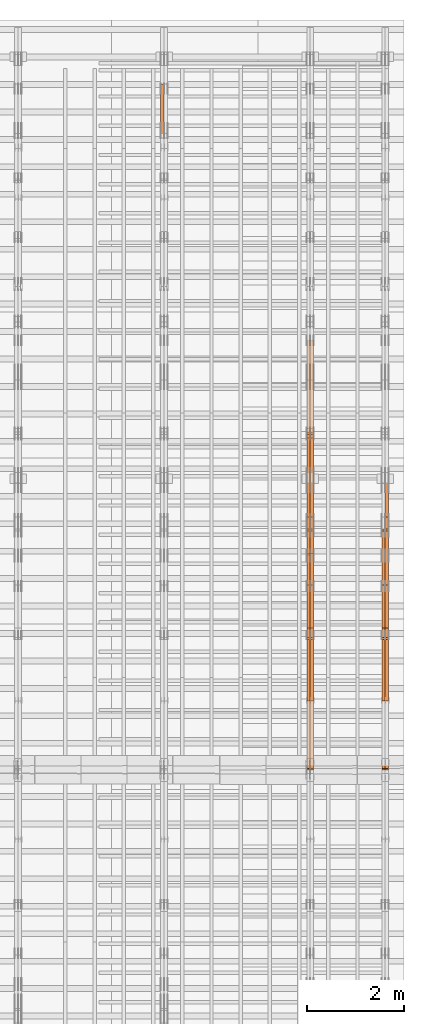
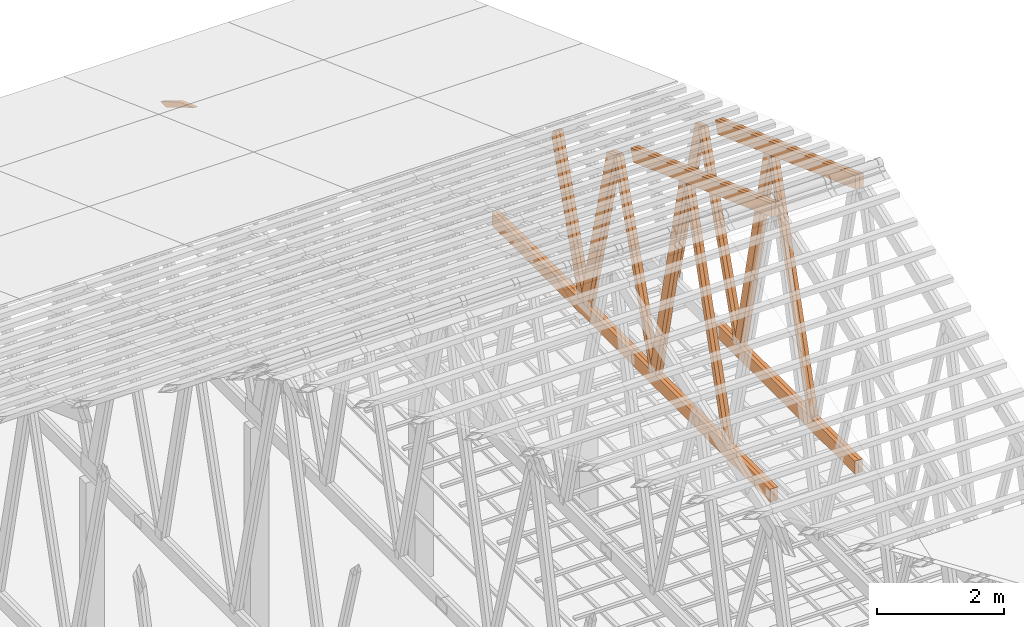
# One storey, part 64 of 189: 28 proxies.
"""IFC2X3 building model written with IfcOpenShell, lengths in millimetres."""

import ifcopenshell
import ifcopenshell.guid

model = None  # the IFC model being written
_history = None  # IfcOwnerHistory: only IFC2X3 demands one
_inside = {}  # id of a spatial element -> (the spatial element, [elements in it])
_under = {}  # id of a project, library or spatial element -> (it, [spatial elements below it])
_declared = {}  # id of a project -> (the project, [libraries it declares])
_typed = {}  # id of a type object -> (the type object, [elements of that type])
_made_of = {}  # id of a material, layer set ... -> (it, [elements and type objects made of it])


def new_model(schema):
    """Start an empty IFC model of exactly this schema.

    Asked for "IFC4X3", IfcOpenShell would pick the latest addendum, in which some entities
    have other attributes; the version numbers below select the first issue.
    IFC2X3 requires an IfcOwnerHistory on every rooted entity: one is made here for all.
    """
    global model, _history
    if schema == "IFC4X3":
        model = ifcopenshell.file(schema_version=(4, 3, 0, 0))
    else:
        model = ifcopenshell.file(schema=schema)
    _inside.clear()
    _under.clear()
    _declared.clear()
    _typed.clear()
    _made_of.clear()
    _history = None
    if model.schema == "IFC2X3":
        org = make("IfcOrganization", Name="unknown")
        user = make(
            "IfcPersonAndOrganization",
            ThePerson=make("IfcPerson", FamilyName="unknown"),
            TheOrganization=org,
        )
        app = make(
            "IfcApplication",
            ApplicationDeveloper=org,
            Version="unknown",
            ApplicationFullName="unknown",
            ApplicationIdentifier="unknown",
        )
        _history = make(
            "IfcOwnerHistory",
            OwningUser=user,
            OwningApplication=app,
            ChangeAction="ADDED",
            CreationDate=0,
        )
    return model


def make(cls, **values):
    """One entity of the class cls with the attributes given. An attribute that is None is left unset."""
    return model.create_entity(
        cls, **{name: value for name, value in values.items() if value is not None}
    )


def entity(cls, *values):
    """Any entity or typed value of the class cls, its attributes in the order of the schema. None: left unset."""
    e = model.create_entity(cls)
    for i, value in enumerate(values):
        if value is not None:
            e[i] = value
    return e


def rooted(cls, **values):
    """An entity with a GlobalId (a new one), such as an element, a storey or a relation."""
    return make(cls, GlobalId=ifcopenshell.guid.new(), OwnerHistory=_history, **values)


def si_unit(unit_type, name, prefix=None):
    """IfcSIUnit, for example si_unit("LENGTHUNIT", "METRE", prefix="MILLI")."""
    return make("IfcSIUnit", UnitType=unit_type, Prefix=prefix, Name=name)


def converted_unit(unit_type, name, factor, base, dimensions=None, offset=None):
    """IfcConversionBasedUnit, such as the inch: factor (a typed value) times the base unit."""
    return make(
        "IfcConversionBasedUnit"
        if offset is None
        else "IfcConversionBasedUnitWithOffset",
        ConversionOffset=offset,
        Dimensions=None
        if dimensions is None
        else entity("IfcDimensionalExponents", *dimensions),
        UnitType=unit_type,
        Name=name,
        ConversionFactor=make(
            "IfcMeasureWithUnit", ValueComponent=factor, UnitComponent=base
        ),
    )


def derived_unit(unit_type, elements):
    """IfcDerivedUnit: a product of units, each with its exponent."""
    return make(
        "IfcDerivedUnit",
        Elements=[
            make("IfcDerivedUnitElement", Unit=unit, Exponent=power)
            for unit, power in elements
        ],
        UnitType=unit_type,
    )


def assignment(units):
    """IfcUnitAssignment: the units of a project."""
    return None if units is None else make("IfcUnitAssignment", Units=units)


def point(xyz):
    """IfcCartesianPoint."""
    return None if xyz is None else make("IfcCartesianPoint", Coordinates=xyz)


def direction(xyz):
    """IfcDirection."""
    return None if xyz is None else make("IfcDirection", DirectionRatios=xyz)


def frame(location, z_axis=None, x_axis=None):
    """IfcAxis2Placement3D, a coordinate frame: its origin and axes. An axis left out is left unset."""
    return make(
        "IfcAxis2Placement3D",
        Location=point(location),
        Axis=direction(z_axis),
        RefDirection=direction(x_axis),
    )


def frame_2d(location, x_axis=None):
    """IfcAxis2Placement2D, a coordinate frame in the plane: its origin and x axis."""
    return make(
        "IfcAxis2Placement2D", Location=point(location), RefDirection=direction(x_axis)
    )


def origin():
    """The frame at (0, 0, 0) with its axes left unset."""
    return frame((0.0, 0.0, 0.0))


def origin_2d_with_axis():
    """The frame at (0, 0) in the plane with the x axis (1, 0) written out."""
    return frame_2d((0.0, 0.0), x_axis=(1.0, 0.0))


def place(relative_to, where):
    """IfcLocalPlacement: puts the frame where relative to a parent placement (None: the world)."""
    return make(
        "IfcLocalPlacement", PlacementRelTo=relative_to, RelativePlacement=where
    )


def context(
    kind, dimensions, precision=None, world=None, true_north=None, identifier=None
):
    """IfcGeometricRepresentationContext, for example the 3D "Model" context."""
    return make(
        "IfcGeometricRepresentationContext",
        ContextIdentifier=identifier,
        ContextType=kind,
        CoordinateSpaceDimension=dimensions,
        Precision=precision,
        WorldCoordinateSystem=world,
        TrueNorth=true_north,
    )


def subcontext(parent, identifier, kind, view, scale=None):
    """IfcGeometricRepresentationSubContext, for example "Body" below "Model"."""
    return make(
        "IfcGeometricRepresentationSubContext",
        ContextIdentifier=identifier,
        ContextType=kind,
        ParentContext=parent,
        TargetScale=scale,
        TargetView=view,
    )


def project(units=None, contexts=None):
    """IfcProject with its units and contexts."""
    return rooted(
        "IfcProject",
        Name="project",
        RepresentationContexts=contexts,
        UnitsInContext=assignment(units),
    )


def spatial(cls, under=None, at=None, **own):
    """A site, building, storey or space (cls), placed at a placement, below another one or the project."""
    s = rooted(cls, ObjectPlacement=at, **own)
    if under is not None:
        _under.setdefault(under.id(), (under, []))[1].append(s)
    return s


def polyline(points):
    """IfcPolyline through the points."""
    return make("IfcPolyline", Points=[point(p) for p in points])


def profile(cls, at=None, kind="AREA", **sizes):
    """A parametric profile (cls). Its sizes go by their IFC names, for example OverallWidth=200.0."""
    return make(cls, ProfileType=kind, Position=at, **sizes)


def rectangle(**sizes):
    """IfcRectangleProfileDef."""
    return profile("IfcRectangleProfileDef", **sizes)


def outline(outer, holes=None, kind="AREA"):
    """IfcArbitraryClosedProfileDef: a profile drawn as a closed curve; with holes, ...WithVoids."""
    if holes is None:
        return make("IfcArbitraryClosedProfileDef", ProfileType=kind, OuterCurve=outer)
    return make(
        "IfcArbitraryProfileDefWithVoids",
        ProfileType=kind,
        OuterCurve=outer,
        InnerCurves=holes,
    )


def extrude(swept, where, along, depth):
    """IfcExtrudedAreaSolid: the profile swept, set in the frame where, extruded along a direction by depth."""
    return make(
        "IfcExtrudedAreaSolid",
        SweptArea=swept,
        Position=where,
        ExtrudedDirection=direction(along),
        Depth=depth,
    )


def shape(context_of_items, identifier, shape_type, items):
    """IfcShapeRepresentation: the items that make up one representation, for example the "Body"."""
    return make(
        "IfcShapeRepresentation",
        ContextOfItems=context_of_items,
        RepresentationIdentifier=identifier,
        RepresentationType=shape_type,
        Items=items,
    )


def source(mapping_origin, context_of_items, identifier, shape_type, items):
    """IfcRepresentationMap: a shape defined once, which mapped items show again and again."""
    return make(
        "IfcRepresentationMap",
        MappingOrigin=mapping_origin,
        MappedRepresentation=shape(context_of_items, identifier, shape_type, items),
    )


def transform(
    local_origin,
    x_axis=None,
    y_axis=None,
    z_axis=None,
    scale=None,
    scale2=None,
    scale3=None,
    uniform=True,
):
    """IfcCartesianTransformationOperator3D, or its non-uniform kind. x_axis, y_axis, z_axis: its Axis1, 2, 3."""
    if uniform:
        return make(
            "IfcCartesianTransformationOperator3D",
            Axis1=direction(x_axis),
            Axis2=direction(y_axis),
            LocalOrigin=point(local_origin),
            Scale=scale,
            Axis3=direction(z_axis),
        )
    return make(
        "IfcCartesianTransformationOperator3DnonUniform",
        Axis1=direction(x_axis),
        Axis2=direction(y_axis),
        LocalOrigin=point(local_origin),
        Scale=scale,
        Axis3=direction(z_axis),
        Scale2=scale2,
        Scale3=scale3,
    )


def mapped(mapping_source, mapping_target):
    """IfcMappedItem: shows the shape of a source again, moved by a transform."""
    return make(
        "IfcMappedItem", MappingSource=mapping_source, MappingTarget=mapping_target
    )


def material(Name=None, Category=None):
    """IfcMaterial."""
    return make("IfcMaterial", Name=Name, Category=Category)


def made_of(thing, what):
    """Note that an element or type object is made of a material, layer set ...; save() writes the relation."""
    if what is not None:
        _made_of.setdefault(what.id(), (what, []))[1].append(thing)
    return thing


def type_object(cls, material=None, **own):
    """A type object (cls), such as IfcWallType, which elements share."""
    return made_of(rooted(cls, **own), material)


def type_shapes(of_type, sources):
    """Give a type object the sources (RepresentationMaps) that its elements show as mapped items."""
    of_type.RepresentationMaps = sources


def element(
    cls,
    number,
    at=None,
    inside=None,
    cuts=None,
    type_object=None,
    material=None,
    context=None,
    identifier="Body",
    shape_type=None,
    held_by="IfcProductDefinitionShape",
    body=None,
    shapes=None,
    **own,
):
    """One element of the class cls, such as IfcWall. Its Tag is "e" and its number.

    at: its placement. inside: the storey or other place that contains it. cuts: it is an
    opening in that element (IfcRelVoidsElement). A single representation is given by context,
    identifier, shape_type and body (its items); several are given by shapes. held_by: the class
    of the entity that holds the representations. save() writes the other relations.
    """
    e = rooted(cls, Tag="e%d" % number, ObjectPlacement=at, **own)
    if body is not None:
        shapes = [shape(context, identifier, shape_type, body)]
    if shapes is not None:
        e.Representation = make(held_by, Representations=shapes)
    if inside is not None:
        _inside.setdefault(inside.id(), (inside, []))[1].append(e)
    if cuts is not None:
        rooted(
            "IfcRelVoidsElement", RelatingBuildingElement=cuts, RelatedOpeningElement=e
        )
    if type_object is not None:
        _typed.setdefault(type_object.id(), (type_object, []))[1].append(e)
    return made_of(e, material)


def aggregate(whole, parts):
    """IfcRelAggregates: a whole, such as a stair, and the parts it consists of."""
    return rooted("IfcRelAggregates", RelatingObject=whole, RelatedObjects=parts)


def save(model, path):
    """Write the relations noted so far, then the file.

    IfcRelAggregates (storeys below a building ...), IfcRelContainedInSpatialStructure (elements
    in a storey), IfcRelDefinesByType, IfcRelAssociatesMaterial and IfcRelDeclares: one each for
    every whole, place, type object, material and project.
    """
    for whole, parts in _under.values():
        aggregate(whole, parts)
    for where, things in _inside.values():
        rooted(
            "IfcRelContainedInSpatialStructure",
            RelatedElements=things,
            RelatingStructure=where,
        )
    for kind, things in _typed.values():
        rooted("IfcRelDefinesByType", RelatedObjects=things, RelatingType=kind)
    for what, things in _made_of.values():
        rooted("IfcRelAssociatesMaterial", RelatedObjects=things, RelatingMaterial=what)
    for by, libraries in _declared.values():
        rooted("IfcRelDeclares", RelatingContext=by, RelatedDefinitions=libraries)
    model.write(path)


model = new_model("IFC2X3")

# Units and contexts
model_context = context("Model", 3, precision=0.01, world=origin(), true_north=direction((6.12303176911189e-17, 1.0)))
body_context = subcontext(model_context, "Body", "Model", "MODEL_VIEW")
ifc_project = project(units=[si_unit("LENGTHUNIT", "METRE", prefix="MILLI"), si_unit("AREAUNIT", "SQUARE_METRE"), si_unit("VOLUMEUNIT", "CUBIC_METRE"), converted_unit("PLANEANGLEUNIT", "DEGREE", entity("IfcRatioMeasure", 0.0174532925199433), si_unit("PLANEANGLEUNIT", "RADIAN"), dimensions=[0, 0, 0, 0, 0, 0, 0]), si_unit("MASSUNIT", "GRAM", prefix="KILO"), derived_unit("MASSDENSITYUNIT", [(si_unit("MASSUNIT", "GRAM", prefix="KILO"), 1), (si_unit("LENGTHUNIT", "METRE"), -3)]), si_unit("TIMEUNIT", "SECOND"), si_unit("FREQUENCYUNIT", "HERTZ"), si_unit("THERMODYNAMICTEMPERATUREUNIT", "DEGREE_CELSIUS"), derived_unit("THERMALTRANSMITTANCEUNIT", [(si_unit("MASSUNIT", "GRAM", prefix="KILO"), 1), (si_unit("THERMODYNAMICTEMPERATUREUNIT", "KELVIN"), -1), (si_unit("TIMEUNIT", "SECOND"), -3)]), derived_unit("VOLUMETRICFLOWRATEUNIT", [(si_unit("LENGTHUNIT", "METRE"), 3), (si_unit("TIMEUNIT", "SECOND"), -1)]), si_unit("ELECTRICCURRENTUNIT", "AMPERE"), si_unit("ELECTRICVOLTAGEUNIT", "VOLT"), si_unit("POWERUNIT", "WATT"), si_unit("FORCEUNIT", "NEWTON"), si_unit("ILLUMINANCEUNIT", "LUX"), si_unit("LUMINOUSFLUXUNIT", "LUMEN"), si_unit("LUMINOUSINTENSITYUNIT", "CANDELA"), derived_unit("USERDEFINED", [(si_unit("MASSUNIT", "GRAM", prefix="KILO"), -1), (si_unit("LENGTHUNIT", "METRE"), -2), (si_unit("TIMEUNIT", "SECOND"), 3), (si_unit("LUMINOUSFLUXUNIT", "LUMEN"), 1)]), derived_unit("LINEARVELOCITYUNIT", [(si_unit("LENGTHUNIT", "METRE"), 1), (si_unit("TIMEUNIT", "SECOND"), -1)]), si_unit("PRESSUREUNIT", "PASCAL"), derived_unit("USERDEFINED", [(si_unit("LENGTHUNIT", "METRE"), -2), (si_unit("MASSUNIT", "GRAM", prefix="KILO"), 1), (si_unit("TIMEUNIT", "SECOND"), -2)])], contexts=[model_context])

# Site, building, storey
site_placement = place(None, origin())
site = spatial("IfcSite", under=ifc_project, at=site_placement, CompositionType="ELEMENT")
building_placement = place(site_placement, origin())
building = spatial("IfcBuilding", under=site, at=building_placement, CompositionType="ELEMENT")
storey_placement = place(building_placement, origin())
storey = spatial("IfcBuildingStorey", under=building, at=storey_placement, Name="Default", CompositionType="ELEMENT", Elevation=0.0)

# Proxies
ifc_material_1 = material(Name="IfcSurfaceStyle #273508")
building_element_proxy_type_1 = type_object("IfcBuildingElementProxyType", Name="T1-W6 273506", PredefinedType="NOTDEFINED", material=ifc_material_1)
shared_shape_1 = source(origin(), body_context, "Body", "SweptSolid", [
    extrude(outline(polyline([(-2668.68989660745, -47.5002238228721), (1800.72567700045, -47.5002238228721), (1797.68490303083, 0.000158637170537834), (1711.12272493628, 47.5001445042868), (-2640.84340836012, 47.5001445042868), (-2668.68989660745, -47.5002238228721)])), frame((1800.7257704503, 47.5001445042868, 0.0), z_axis=(0.0, 0.0, 1.0), x_axis=(-1.0, 0.0, 0.0)), (0.0, 0.0, 1.0), 69.9999999999997),
])
type_shapes(building_element_proxy_type_1, [shared_shape_1])
proxy_1_placement = place(building_placement, frame((49840.0, 17516.8749791841, 4507.23620831254), z_axis=(-1.0, 0.0, 0.0), x_axis=(0.0, -0.281285983104611, -0.959623986626466)))
element("IfcBuildingElementProxy", 1, at=proxy_1_placement, inside=storey, type_object=building_element_proxy_type_1, material=ifc_material_1, Name="T1-W6", context=body_context, shape_type="MappedRepresentation", body=[
    mapped(shared_shape_1, transform((0.0, 0.0, 0.0), scale=1.0)),
])
ifc_material_2 = material(Name="IfcSurfaceStyle #273442")
building_element_proxy_type_2 = type_object("IfcBuildingElementProxyType", Name="T1-W6 273440", PredefinedType="NOTDEFINED", material=ifc_material_2)
shared_shape_2 = source(origin(), body_context, "Body", "SweptSolid", [
    extrude(outline(polyline([(-2668.68989660745, -47.5002238228721), (1800.72567700045, -47.5002238228721), (1797.68490303083, 0.000158637170537834), (1711.12272493628, 47.5001445042868), (-2640.84340836012, 47.5001445042868), (-2668.68989660745, -47.5002238228721)])), frame((1800.7257704503, 47.5001445042868, 0.0), z_axis=(0.0, 0.0, 1.0), x_axis=(-1.0, 0.0, 0.0)), (0.0, 0.0, 1.0), 69.9999999999997),
])
type_shapes(building_element_proxy_type_2, [shared_shape_2])
proxy_2_placement = place(building_placement, frame((49770.0, 17516.8749791841, 4507.23620831254), z_axis=(-1.0, 0.0, 0.0), x_axis=(0.0, -0.281285983104611, -0.959623986626466)))
element("IfcBuildingElementProxy", 2, at=proxy_2_placement, inside=storey, type_object=building_element_proxy_type_2, material=ifc_material_2, Name="T1-W6", context=body_context, shape_type="MappedRepresentation", body=[
    mapped(shared_shape_2, transform((0.0, 0.0, 0.0), scale=1.0)),
])
ifc_material_3 = material(Name="IfcSurfaceStyle #273244")
building_element_proxy_type_3 = type_object("IfcBuildingElementProxyType", Name="T1-W3 273242", PredefinedType="NOTDEFINED", material=ifc_material_3)
shared_shape_3 = source(origin(), body_context, "Body", "SweptSolid", [
    extrude(outline(polyline([(-2517.58938959787, -85.0001104675026), (1625.445846867, -85.0001104675027), (1768.20563426494, 0.000209440697654673), (1749.48871563991, 85.0000057471538), (-2625.55080717397, 85.0000057471538), (-2517.58938959787, -85.0001104675026)])), frame((1768.2056683344, 85.0000547211315, 0.0), z_axis=(0.0, 0.0, 1.0), x_axis=(-1.0, 0.0, 0.0)), (0.0, 0.0, 1.0), 69.9999999999997),
])
type_shapes(building_element_proxy_type_3, [shared_shape_3])
proxy_3_placement = place(building_placement, frame((49840.0, 18415.3042863408, 226.720947016584), z_axis=(-1.0, 0.0, 0.0), x_axis=(0.0, -0.215047682154604, 0.976603550269982)))
element("IfcBuildingElementProxy", 3, at=proxy_3_placement, inside=storey, type_object=building_element_proxy_type_3, material=ifc_material_3, Name="T1-W3", context=body_context, shape_type="MappedRepresentation", body=[
    mapped(shared_shape_3, transform((0.0, 0.0, 0.0), scale=1.0)),
])
ifc_material_4 = material(Name="IfcSurfaceStyle #273178")
building_element_proxy_type_4 = type_object("IfcBuildingElementProxyType", Name="T1-W3 273176", PredefinedType="NOTDEFINED", material=ifc_material_4)
shared_shape_4 = source(origin(), body_context, "Body", "SweptSolid", [
    extrude(outline(polyline([(-2517.58938959787, -85.0001104675026), (1625.445846867, -85.0001104675027), (1768.20563426494, 0.000209440697654673), (1749.48871563991, 85.0000057471538), (-2625.55080717397, 85.0000057471538), (-2517.58938959787, -85.0001104675026)])), frame((1768.2056683344, 85.0000547211315, 0.0), z_axis=(0.0, 0.0, 1.0), x_axis=(-1.0, 0.0, 0.0)), (0.0, 0.0, 1.0), 69.9999999999997),
])
type_shapes(building_element_proxy_type_4, [shared_shape_4])
proxy_4_placement = place(building_placement, frame((49770.0, 18415.3042863408, 226.720947016584), z_axis=(-1.0, 0.0, 0.0), x_axis=(0.0, -0.215047682154604, 0.976603550269982)))
element("IfcBuildingElementProxy", 4, at=proxy_4_placement, inside=storey, type_object=building_element_proxy_type_4, material=ifc_material_4, Name="T1-W3", context=body_context, shape_type="MappedRepresentation", body=[
    mapped(shared_shape_4, transform((0.0, 0.0, 0.0), scale=1.0)),
])
ifc_material_5 = material(Name="IfcSurfaceStyle #272980")
building_element_proxy_type_5 = type_object("IfcBuildingElementProxyType", Name="T1-W7 272978", PredefinedType="NOTDEFINED", material=ifc_material_5)
shared_shape_5 = source(origin(), body_context, "Body", "SweptSolid", [
    extrude(outline(polyline([(-2189.6662270939, -47.5000140805343), (1475.30081553583, -47.5000140805343), (1473.93388518462, 0.00042343352179337), (1398.58463533215, 47.4998023637734), (-2158.15310895869, 47.4998023637734), (-2189.6662270939, -47.5000140805343)])), frame((1475.30081553583, 47.5004895824757, 0.0), z_axis=(0.0, 0.0, 1.0), x_axis=(-1.0, 0.0, 0.0)), (0.0, 0.0, 1.0), 69.9999999999998),
])
type_shapes(building_element_proxy_type_5, [shared_shape_5])
proxy_5_placement = place(building_placement, frame((49840.0, 19742.3819153401, 3693.66743808885), z_axis=(-1.0, 0.0, 0.0), x_axis=(0.0, -0.314845237923104, -0.949143021971475)))
element("IfcBuildingElementProxy", 5, at=proxy_5_placement, inside=storey, type_object=building_element_proxy_type_5, material=ifc_material_5, Name="T1-W7", context=body_context, shape_type="MappedRepresentation", body=[
    mapped(shared_shape_5, transform((0.0, 0.0, 0.0), scale=1.0)),
])
ifc_material_6 = material(Name="IfcSurfaceStyle #272914")
building_element_proxy_type_6 = type_object("IfcBuildingElementProxyType", Name="T1-W7 272912", PredefinedType="NOTDEFINED", material=ifc_material_6)
shared_shape_6 = source(origin(), body_context, "Body", "SweptSolid", [
    extrude(outline(polyline([(-2189.6662270939, -47.5000140805343), (1475.30081553583, -47.5000140805343), (1473.93388518462, 0.00042343352179337), (1398.58463533215, 47.4998023637734), (-2158.15310895869, 47.4998023637734), (-2189.6662270939, -47.5000140805343)])), frame((1475.30081553583, 47.5004895824757, 0.0), z_axis=(0.0, 0.0, 1.0), x_axis=(-1.0, 0.0, 0.0)), (0.0, 0.0, 1.0), 69.9999999999998),
])
type_shapes(building_element_proxy_type_6, [shared_shape_6])
proxy_6_placement = place(building_placement, frame((49770.0, 19742.3819153401, 3693.66743808885), z_axis=(-1.0, 0.0, 0.0), x_axis=(0.0, -0.314845237923104, -0.949143021971475)))
element("IfcBuildingElementProxy", 6, at=proxy_6_placement, inside=storey, type_object=building_element_proxy_type_6, material=ifc_material_6, Name="T1-W7", context=body_context, shape_type="MappedRepresentation", body=[
    mapped(shared_shape_6, transform((0.0, 0.0, 0.0), scale=1.0)),
])
ifc_material_7 = material(Name="IfcSurfaceStyle #272716")
building_element_proxy_type_7 = type_object("IfcBuildingElementProxyType", Name="T1-W1 272714", PredefinedType="NOTDEFINED", material=ifc_material_7)
shared_shape_7 = source(origin(), body_context, "Body", "SweptSolid", [
    extrude(outline(polyline([(-1996.99427801396, -109.999889649051), (1271.09905152223, -109.999889649051), (1448.88120817726, -0.000113190727324008), (1421.70802776002, 109.999946244415), (-2144.69400944554, 109.999946244415), (-1996.99427801396, -109.999889649051)])), frame((1448.88120817726, 110.000265670598, 0.0), z_axis=(0.0, 0.0, 1.0), x_axis=(-1.0, 0.0, 0.0)), (0.0, 0.0, 1.0), 69.9999999999998),
])
type_shapes(building_element_proxy_type_7, [shared_shape_7])
proxy_7_placement = place(building_placement, frame((49840.0, 20558.6774904859, 218.61972674968), z_axis=(-1.0, 0.0, 0.0), x_axis=(0.0, -0.239819839925979, 0.970817410421691)))
element("IfcBuildingElementProxy", 7, at=proxy_7_placement, inside=storey, type_object=building_element_proxy_type_7, material=ifc_material_7, Name="T1-W1", context=body_context, shape_type="MappedRepresentation", body=[
    mapped(shared_shape_7, transform((0.0, 0.0, 0.0), scale=1.0)),
])
ifc_material_8 = material(Name="IfcSurfaceStyle #269734")
building_element_proxy_type_8 = type_object("IfcBuildingElementProxyType", Name="T1-B5 269732", PredefinedType="NOTDEFINED", material=ifc_material_8)
shared_shape_8 = source(origin(), body_context, "Body", "SweptSolid", [
    extrude(rectangle(XDim=4381.5, YDim=245.000000000001, at=origin_2d_with_axis()), frame((2190.75, 122.5, 0.0), z_axis=(0.0, 0.0, 1.0), x_axis=(-1.0, 0.0, 0.0)), (0.0, 0.0, 1.0), 69.9999999999997),
])
type_shapes(building_element_proxy_type_8, [shared_shape_8])
proxy_8_placement = place(building_placement, frame((49840.0, 14780.2587890625, 245.0), z_axis=(-1.0, 0.0, 0.0), x_axis=(0.0, 1.0, 0.0)))
element("IfcBuildingElementProxy", 8, at=proxy_8_placement, inside=storey, type_object=building_element_proxy_type_8, material=ifc_material_8, Name="T1-B5", context=body_context, shape_type="MappedRepresentation", body=[
    mapped(shared_shape_8, transform((0.0, 0.0, 0.0), scale=1.0)),
])
ifc_material_9 = material(Name="IfcSurfaceStyle #269677")
building_element_proxy_type_9 = type_object("IfcBuildingElementProxyType", Name="T1-B5 269675", PredefinedType="NOTDEFINED", material=ifc_material_9)
shared_shape_9 = source(origin(), body_context, "Body", "SweptSolid", [
    extrude(rectangle(XDim=4381.5, YDim=245.000000000001, at=origin_2d_with_axis()), frame((2190.75, 122.5, 0.0), z_axis=(0.0, 0.0, 1.0), x_axis=(-1.0, 0.0, 0.0)), (0.0, 0.0, 1.0), 69.9999999999997),
])
type_shapes(building_element_proxy_type_9, [shared_shape_9])
proxy_9_placement = place(building_placement, frame((49770.0, 14780.2587890625, 245.0), z_axis=(-1.0, 0.0, 0.0), x_axis=(0.0, 1.0, 0.0)))
element("IfcBuildingElementProxy", 9, at=proxy_9_placement, inside=storey, type_object=building_element_proxy_type_9, material=ifc_material_9, Name="T1-B5", context=body_context, shape_type="MappedRepresentation", body=[
    mapped(shared_shape_9, transform((0.0, 0.0, 0.0), scale=1.0)),
])
ifc_material_10 = material(Name="IfcSurfaceStyle #268918")
building_element_proxy_type_10 = type_object("IfcBuildingElementProxyType", Name="T1-T3 268916", PredefinedType="NOTDEFINED", material=ifc_material_10)
shared_shape_10 = source(origin(), body_context, "Body", "SweptSolid", [
    extrude(outline(polyline([(-2386.23525922045, -122.500022994835), (2341.64890001386, -122.500022994835), (2341.64888416412, 122.500022994835), (-2297.06252495753, 122.500022994835), (-2386.23525922045, -122.500022994835)])), frame((2341.64890001386, 122.500051926629, 0.0), z_axis=(0.0, 0.0, 1.0), x_axis=(-1.0, 0.0, 0.0)), (0.0, 0.0, 1.0), 69.9999999999997),
])
type_shapes(building_element_proxy_type_10, [shared_shape_10])
proxy_10_placement = place(building_placement, frame((49840.0, 19108.9628956236, 3921.30465489208), z_axis=(-1.0, 0.0, 0.0), x_axis=(0.0, -0.939692620785908, 0.342020143325669)))
element("IfcBuildingElementProxy", 10, at=proxy_10_placement, inside=storey, type_object=building_element_proxy_type_10, material=ifc_material_10, Name="T1-T3", context=body_context, shape_type="MappedRepresentation", body=[
    mapped(shared_shape_10, transform((0.0, 0.0, 0.0), scale=1.0)),
])
ifc_material_11 = material(Name="IfcSurfaceStyle #268861")
building_element_proxy_type_11 = type_object("IfcBuildingElementProxyType", Name="T1-T3 268859", PredefinedType="NOTDEFINED", material=ifc_material_11)
shared_shape_11 = source(origin(), body_context, "Body", "SweptSolid", [
    extrude(outline(polyline([(-2386.23525922045, -122.500022994835), (2341.64890001386, -122.500022994835), (2341.64888416412, 122.500022994835), (-2297.06252495753, 122.500022994835), (-2386.23525922045, -122.500022994835)])), frame((2341.64890001386, 122.500051926629, 0.0), z_axis=(0.0, 0.0, 1.0), x_axis=(-1.0, 0.0, 0.0)), (0.0, 0.0, 1.0), 69.9999999999997),
])
type_shapes(building_element_proxy_type_11, [shared_shape_11])
proxy_11_placement = place(building_placement, frame((49770.0, 19108.9628956236, 3921.30465489208), z_axis=(-1.0, 0.0, 0.0), x_axis=(0.0, -0.939692620785908, 0.342020143325669)))
element("IfcBuildingElementProxy", 11, at=proxy_11_placement, inside=storey, type_object=building_element_proxy_type_11, material=ifc_material_11, Name="T1-T3", context=body_context, shape_type="MappedRepresentation", body=[
    mapped(shared_shape_11, transform((0.0, 0.0, 0.0), scale=1.0)),
])
ifc_material_12 = material(Name="IfcSurfaceStyle #257718")
building_element_proxy_type_12 = type_object("IfcBuildingElementProxyType", Name="T1-W6 257716", PredefinedType="NOTDEFINED", material=ifc_material_12)
shared_shape_12 = source(origin(), body_context, "Body", "SweptSolid", [
    extrude(outline(polyline([(-2668.68989660745, -47.5002238228721), (1800.72567700045, -47.5002238228721), (1797.68490303083, 0.000158637170537834), (1711.12272493628, 47.5001445042868), (-2640.84340836012, 47.5001445042868), (-2668.68989660745, -47.5002238228721)])), frame((1800.7257704503, 47.5001445042868, 0.0), z_axis=(0.0, 0.0, 1.0), x_axis=(-1.0, 0.0, 0.0)), (0.0, 0.0, 1.0), 69.9999999999997),
])
type_shapes(building_element_proxy_type_12, [shared_shape_12])
proxy_12_placement = place(building_placement, frame((48300.0, 17516.8749791841, 4507.23620831254), z_axis=(-1.0, 0.0, 0.0), x_axis=(0.0, -0.281285983104611, -0.959623986626466)))
element("IfcBuildingElementProxy", 12, at=proxy_12_placement, inside=storey, type_object=building_element_proxy_type_12, material=ifc_material_12, Name="T1-W6", context=body_context, shape_type="MappedRepresentation", body=[
    mapped(shared_shape_12, transform((0.0, 0.0, 0.0), scale=1.0)),
])
ifc_material_13 = material(Name="IfcSurfaceStyle #257652")
building_element_proxy_type_13 = type_object("IfcBuildingElementProxyType", Name="T1-W6 257650", PredefinedType="NOTDEFINED", material=ifc_material_13)
shared_shape_13 = source(origin(), body_context, "Body", "SweptSolid", [
    extrude(outline(polyline([(-2668.68989660745, -47.5002238228721), (1800.72567700045, -47.5002238228721), (1797.68490303083, 0.000158637170537834), (1711.12272493628, 47.5001445042868), (-2640.84340836012, 47.5001445042868), (-2668.68989660745, -47.5002238228721)])), frame((1800.7257704503, 47.5001445042868, 0.0), z_axis=(0.0, 0.0, 1.0), x_axis=(-1.0, 0.0, 0.0)), (0.0, 0.0, 1.0), 69.9999999999997),
])
type_shapes(building_element_proxy_type_13, [shared_shape_13])
proxy_13_placement = place(building_placement, frame((48230.0, 17516.8749791841, 4507.23620831254), z_axis=(-1.0, 0.0, 0.0), x_axis=(0.0, -0.281285983104611, -0.959623986626466)))
element("IfcBuildingElementProxy", 13, at=proxy_13_placement, inside=storey, type_object=building_element_proxy_type_13, material=ifc_material_13, Name="T1-W6", context=body_context, shape_type="MappedRepresentation", body=[
    mapped(shared_shape_13, transform((0.0, 0.0, 0.0), scale=1.0)),
])
ifc_material_14 = material(Name="IfcSurfaceStyle #257454")
building_element_proxy_type_14 = type_object("IfcBuildingElementProxyType", Name="T1-W3 257452", PredefinedType="NOTDEFINED", material=ifc_material_14)
shared_shape_14 = source(origin(), body_context, "Body", "SweptSolid", [
    extrude(outline(polyline([(-2517.58938959787, -85.0001104675026), (1625.445846867, -85.0001104675027), (1768.20563426494, 0.000209440697654673), (1749.48871563991, 85.0000057471538), (-2625.55080717397, 85.0000057471538), (-2517.58938959787, -85.0001104675026)])), frame((1768.2056683344, 85.0000547211315, 0.0), z_axis=(0.0, 0.0, 1.0), x_axis=(-1.0, 0.0, 0.0)), (0.0, 0.0, 1.0), 69.9999999999997),
])
type_shapes(building_element_proxy_type_14, [shared_shape_14])
proxy_14_placement = place(building_placement, frame((48300.0, 18415.3042863408, 226.720947016584), z_axis=(-1.0, 0.0, 0.0), x_axis=(0.0, -0.215047682154604, 0.976603550269982)))
element("IfcBuildingElementProxy", 14, at=proxy_14_placement, inside=storey, type_object=building_element_proxy_type_14, material=ifc_material_14, Name="T1-W3", context=body_context, shape_type="MappedRepresentation", body=[
    mapped(shared_shape_14, transform((0.0, 0.0, 0.0), scale=1.0)),
])
ifc_material_15 = material(Name="IfcSurfaceStyle #257388")
building_element_proxy_type_15 = type_object("IfcBuildingElementProxyType", Name="T1-W3 257386", PredefinedType="NOTDEFINED", material=ifc_material_15)
shared_shape_15 = source(origin(), body_context, "Body", "SweptSolid", [
    extrude(outline(polyline([(-2517.58938959787, -85.0001104675026), (1625.445846867, -85.0001104675027), (1768.20563426494, 0.000209440697654673), (1749.48871563991, 85.0000057471538), (-2625.55080717397, 85.0000057471538), (-2517.58938959787, -85.0001104675026)])), frame((1768.2056683344, 85.0000547211315, 0.0), z_axis=(0.0, 0.0, 1.0), x_axis=(-1.0, 0.0, 0.0)), (0.0, 0.0, 1.0), 69.9999999999997),
])
type_shapes(building_element_proxy_type_15, [shared_shape_15])
proxy_15_placement = place(building_placement, frame((48230.0, 18415.3042863408, 226.720947016584), z_axis=(-1.0, 0.0, 0.0), x_axis=(0.0, -0.215047682154604, 0.976603550269982)))
element("IfcBuildingElementProxy", 15, at=proxy_15_placement, inside=storey, type_object=building_element_proxy_type_15, material=ifc_material_15, Name="T1-W3", context=body_context, shape_type="MappedRepresentation", body=[
    mapped(shared_shape_15, transform((0.0, 0.0, 0.0), scale=1.0)),
])
ifc_material_16 = material(Name="IfcSurfaceStyle #257190")
building_element_proxy_type_16 = type_object("IfcBuildingElementProxyType", Name="T1-W7 257188", PredefinedType="NOTDEFINED", material=ifc_material_16)
shared_shape_16 = source(origin(), body_context, "Body", "SweptSolid", [
    extrude(outline(polyline([(-2189.6662270939, -47.5000140805343), (1475.30081553583, -47.5000140805343), (1473.93388518462, 0.00042343352179337), (1398.58463533215, 47.4998023637734), (-2158.15310895869, 47.4998023637734), (-2189.6662270939, -47.5000140805343)])), frame((1475.30081553583, 47.5004895824757, 0.0), z_axis=(0.0, 0.0, 1.0), x_axis=(-1.0, 0.0, 0.0)), (0.0, 0.0, 1.0), 69.9999999999998),
])
type_shapes(building_element_proxy_type_16, [shared_shape_16])
proxy_16_placement = place(building_placement, frame((48300.0, 19742.3819153401, 3693.66743808885), z_axis=(-1.0, 0.0, 0.0), x_axis=(0.0, -0.314845237923104, -0.949143021971475)))
element("IfcBuildingElementProxy", 16, at=proxy_16_placement, inside=storey, type_object=building_element_proxy_type_16, material=ifc_material_16, Name="T1-W7", context=body_context, shape_type="MappedRepresentation", body=[
    mapped(shared_shape_16, transform((0.0, 0.0, 0.0), scale=1.0)),
])
ifc_material_17 = material(Name="IfcSurfaceStyle #257124")
building_element_proxy_type_17 = type_object("IfcBuildingElementProxyType", Name="T1-W7 257122", PredefinedType="NOTDEFINED", material=ifc_material_17)
shared_shape_17 = source(origin(), body_context, "Body", "SweptSolid", [
    extrude(outline(polyline([(-2189.6662270939, -47.5000140805343), (1475.30081553583, -47.5000140805343), (1473.93388518462, 0.00042343352179337), (1398.58463533215, 47.4998023637734), (-2158.15310895869, 47.4998023637734), (-2189.6662270939, -47.5000140805343)])), frame((1475.30081553583, 47.5004895824757, 0.0), z_axis=(0.0, 0.0, 1.0), x_axis=(-1.0, 0.0, 0.0)), (0.0, 0.0, 1.0), 69.9999999999998),
])
type_shapes(building_element_proxy_type_17, [shared_shape_17])
proxy_17_placement = place(building_placement, frame((48230.0, 19742.3819153401, 3693.66743808885), z_axis=(-1.0, 0.0, 0.0), x_axis=(0.0, -0.314845237923104, -0.949143021971475)))
element("IfcBuildingElementProxy", 17, at=proxy_17_placement, inside=storey, type_object=building_element_proxy_type_17, material=ifc_material_17, Name="T1-W7", context=body_context, shape_type="MappedRepresentation", body=[
    mapped(shared_shape_17, transform((0.0, 0.0, 0.0), scale=1.0)),
])
ifc_material_18 = material(Name="IfcSurfaceStyle #256926")
building_element_proxy_type_18 = type_object("IfcBuildingElementProxyType", Name="T1-W1 256924", PredefinedType="NOTDEFINED", material=ifc_material_18)
shared_shape_18 = source(origin(), body_context, "Body", "SweptSolid", [
    extrude(outline(polyline([(-1996.99427801396, -109.999889649051), (1271.09905152223, -109.999889649051), (1448.88120817726, -0.000113190727324008), (1421.70802776002, 109.999946244415), (-2144.69400944554, 109.999946244415), (-1996.99427801396, -109.999889649051)])), frame((1448.88120817726, 110.000265670598, 0.0), z_axis=(0.0, 0.0, 1.0), x_axis=(-1.0, 0.0, 0.0)), (0.0, 0.0, 1.0), 69.9999999999998),
])
type_shapes(building_element_proxy_type_18, [shared_shape_18])
proxy_18_placement = place(building_placement, frame((48300.0, 20558.6774904859, 218.61972674968), z_axis=(-1.0, 0.0, 0.0), x_axis=(0.0, -0.239819839925979, 0.970817410421691)))
element("IfcBuildingElementProxy", 18, at=proxy_18_placement, inside=storey, type_object=building_element_proxy_type_18, material=ifc_material_18, Name="T1-W1", context=body_context, shape_type="MappedRepresentation", body=[
    mapped(shared_shape_18, transform((0.0, 0.0, 0.0), scale=1.0)),
])
ifc_material_19 = material(Name="IfcSurfaceStyle #256860")
building_element_proxy_type_19 = type_object("IfcBuildingElementProxyType", Name="T1-W1 256858", PredefinedType="NOTDEFINED", material=ifc_material_19)
shared_shape_19 = source(origin(), body_context, "Body", "SweptSolid", [
    extrude(outline(polyline([(-1996.99427801396, -109.999889649051), (1271.09905152223, -109.999889649051), (1448.88120817726, -0.000113190727324008), (1421.70802776002, 109.999946244415), (-2144.69400944554, 109.999946244415), (-1996.99427801396, -109.999889649051)])), frame((1448.88120817726, 110.000265670598, 0.0), z_axis=(0.0, 0.0, 1.0), x_axis=(-1.0, 0.0, 0.0)), (0.0, 0.0, 1.0), 69.9999999999998),
])
type_shapes(building_element_proxy_type_19, [shared_shape_19])
proxy_19_placement = place(building_placement, frame((48230.0, 20558.6774904859, 218.61972674968), z_axis=(-1.0, 0.0, 0.0), x_axis=(0.0, -0.239819839925979, 0.970817410421691)))
element("IfcBuildingElementProxy", 19, at=proxy_19_placement, inside=storey, type_object=building_element_proxy_type_19, material=ifc_material_19, Name="T1-W1", context=body_context, shape_type="MappedRepresentation", body=[
    mapped(shared_shape_19, transform((0.0, 0.0, 0.0), scale=1.0)),
])
ifc_material_20 = material(Name="IfcSurfaceStyle #256662")
building_element_proxy_type_20 = type_object("IfcBuildingElementProxyType", Name="T1-W4 256660", PredefinedType="NOTDEFINED", material=ifc_material_20)
shared_shape_20 = source(origin(), body_context, "Body", "SweptSolid", [
    extrude(outline(polyline([(-1742.90513395849, -84.9997422414737), (1181.3544167489, -84.9997422414737), (1178.19398821251, -0.000208932978430543), (1071.44989130457, 84.999846707963), (-1688.09316230749, 84.999846707963), (-1742.90513395849, -84.9997422414737)])), frame((1181.35452116422, 84.999886337523, 0.0), z_axis=(0.0, 0.0, 1.0), x_axis=(-1.0, 0.0, 0.0)), (0.0, 0.0, 1.0), 69.9999999999998),
])
type_shapes(building_element_proxy_type_20, [shared_shape_20])
proxy_20_placement = place(building_placement, frame((48300.0, 21724.6281517871, 2976.00232464744), z_axis=(-1.0, 0.0, 0.0), x_axis=(0.0, -0.306868406216495, -0.951751953644514)))
element("IfcBuildingElementProxy", 20, at=proxy_20_placement, inside=storey, type_object=building_element_proxy_type_20, material=ifc_material_20, Name="T1-W4", context=body_context, shape_type="MappedRepresentation", body=[
    mapped(shared_shape_20, transform((0.0, 0.0, 0.0), scale=1.0)),
])
ifc_material_21 = material(Name="IfcSurfaceStyle #256596")
building_element_proxy_type_21 = type_object("IfcBuildingElementProxyType", Name="T1-W4 256594", PredefinedType="NOTDEFINED", material=ifc_material_21)
shared_shape_21 = source(origin(), body_context, "Body", "SweptSolid", [
    extrude(outline(polyline([(-1742.90513395849, -84.9997422414737), (1181.3544167489, -84.9997422414737), (1178.19398821251, -0.000208932978430543), (1071.44989130457, 84.999846707963), (-1688.09316230749, 84.999846707963), (-1742.90513395849, -84.9997422414737)])), frame((1181.35452116422, 84.999886337523, 0.0), z_axis=(0.0, 0.0, 1.0), x_axis=(-1.0, 0.0, 0.0)), (0.0, 0.0, 1.0), 69.9999999999998),
])
type_shapes(building_element_proxy_type_21, [shared_shape_21])
proxy_21_placement = place(building_placement, frame((48230.0, 21724.6281517871, 2976.00232464744), z_axis=(-1.0, 0.0, 0.0), x_axis=(0.0, -0.306868406216495, -0.951751953644514)))
element("IfcBuildingElementProxy", 21, at=proxy_21_placement, inside=storey, type_object=building_element_proxy_type_21, material=ifc_material_21, Name="T1-W4", context=body_context, shape_type="MappedRepresentation", body=[
    mapped(shared_shape_21, transform((0.0, 0.0, 0.0), scale=1.0)),
])
ifc_material_22 = material(Name="IfcSurfaceStyle #254058")
building_element_proxy_type_22 = type_object("IfcBuildingElementProxyType", Name="T1-B4 254056", PredefinedType="NOTDEFINED", material=ifc_material_22)
shared_shape_22 = source(origin(), body_context, "Body", "SweptSolid", [
    extrude(rectangle(XDim=4408.2412109375, YDim=245.000000000001, at=origin_2d_with_axis()), frame((2204.12060546875, 122.5, 0.0), z_axis=(0.0, 0.0, 1.0), x_axis=(-1.0, 0.0, 0.0)), (0.0, 0.0, 1.0), 69.9999999999997),
])
type_shapes(building_element_proxy_type_22, [shared_shape_22])
proxy_22_placement = place(building_placement, frame((48300.0, 19161.7587890625, 245.0), z_axis=(-1.0, 0.0, 0.0), x_axis=(0.0, 1.0, 0.0)))
element("IfcBuildingElementProxy", 22, at=proxy_22_placement, inside=storey, type_object=building_element_proxy_type_22, material=ifc_material_22, Name="T1-B4", context=body_context, shape_type="MappedRepresentation", body=[
    mapped(shared_shape_22, transform((0.0, 0.0, 0.0), scale=1.0)),
])
ifc_material_23 = material(Name="IfcSurfaceStyle #254001")
building_element_proxy_type_23 = type_object("IfcBuildingElementProxyType", Name="T1-B4 253999", PredefinedType="NOTDEFINED", material=ifc_material_23)
shared_shape_23 = source(origin(), body_context, "Body", "SweptSolid", [
    extrude(rectangle(XDim=4408.2412109375, YDim=245.000000000001, at=origin_2d_with_axis()), frame((2204.12060546875, 122.5, 0.0), z_axis=(0.0, 0.0, 1.0), x_axis=(-1.0, 0.0, 0.0)), (0.0, 0.0, 1.0), 69.9999999999997),
])
type_shapes(building_element_proxy_type_23, [shared_shape_23])
proxy_23_placement = place(building_placement, frame((48230.0, 19161.7587890625, 245.0), z_axis=(-1.0, 0.0, 0.0), x_axis=(0.0, 1.0, 0.0)))
element("IfcBuildingElementProxy", 23, at=proxy_23_placement, inside=storey, type_object=building_element_proxy_type_23, material=ifc_material_23, Name="T1-B4", context=body_context, shape_type="MappedRepresentation", body=[
    mapped(shared_shape_23, transform((0.0, 0.0, 0.0), scale=1.0)),
])
ifc_material_24 = material(Name="IfcSurfaceStyle #253944")
building_element_proxy_type_24 = type_object("IfcBuildingElementProxyType", Name="T1-B5 253942", PredefinedType="NOTDEFINED", material=ifc_material_24)
shared_shape_24 = source(origin(), body_context, "Body", "SweptSolid", [
    extrude(rectangle(XDim=4381.5, YDim=245.000000000001, at=origin_2d_with_axis()), frame((2190.75, 122.5, 0.0), z_axis=(0.0, 0.0, 1.0), x_axis=(-1.0, 0.0, 0.0)), (0.0, 0.0, 1.0), 69.9999999999997),
])
type_shapes(building_element_proxy_type_24, [shared_shape_24])
proxy_24_placement = place(building_placement, frame((48300.0, 14780.2587890625, 245.0), z_axis=(-1.0, 0.0, 0.0), x_axis=(0.0, 1.0, 0.0)))
element("IfcBuildingElementProxy", 24, at=proxy_24_placement, inside=storey, type_object=building_element_proxy_type_24, material=ifc_material_24, Name="T1-B5", context=body_context, shape_type="MappedRepresentation", body=[
    mapped(shared_shape_24, transform((0.0, 0.0, 0.0), scale=1.0)),
])
ifc_material_25 = material(Name="IfcSurfaceStyle #253887")
building_element_proxy_type_25 = type_object("IfcBuildingElementProxyType", Name="T1-B5 253885", PredefinedType="NOTDEFINED", material=ifc_material_25)
shared_shape_25 = source(origin(), body_context, "Body", "SweptSolid", [
    extrude(rectangle(XDim=4381.5, YDim=245.000000000001, at=origin_2d_with_axis()), frame((2190.75, 122.5, 0.0), z_axis=(0.0, 0.0, 1.0), x_axis=(-1.0, 0.0, 0.0)), (0.0, 0.0, 1.0), 69.9999999999997),
])
type_shapes(building_element_proxy_type_25, [shared_shape_25])
proxy_25_placement = place(building_placement, frame((48230.0, 14780.2587890625, 245.0), z_axis=(-1.0, 0.0, 0.0), x_axis=(0.0, 1.0, 0.0)))
element("IfcBuildingElementProxy", 25, at=proxy_25_placement, inside=storey, type_object=building_element_proxy_type_25, material=ifc_material_25, Name="T1-B5", context=body_context, shape_type="MappedRepresentation", body=[
    mapped(shared_shape_25, transform((0.0, 0.0, 0.0), scale=1.0)),
])
ifc_material_26 = material(Name="IfcSurfaceStyle #253128")
building_element_proxy_type_26 = type_object("IfcBuildingElementProxyType", Name="T1-T3 253126", PredefinedType="NOTDEFINED", material=ifc_material_26)
shared_shape_26 = source(origin(), body_context, "Body", "SweptSolid", [
    extrude(outline(polyline([(-2386.23525922045, -122.500022994835), (2341.64890001386, -122.500022994835), (2341.64888416412, 122.500022994835), (-2297.06252495753, 122.500022994835), (-2386.23525922045, -122.500022994835)])), frame((2341.64890001386, 122.500051926629, 0.0), z_axis=(0.0, 0.0, 1.0), x_axis=(-1.0, 0.0, 0.0)), (0.0, 0.0, 1.0), 69.9999999999997),
])
type_shapes(building_element_proxy_type_26, [shared_shape_26])
proxy_26_placement = place(building_placement, frame((48300.0, 19108.9628956236, 3921.30465489208), z_axis=(-1.0, 0.0, 0.0), x_axis=(0.0, -0.939692620785908, 0.342020143325669)))
element("IfcBuildingElementProxy", 26, at=proxy_26_placement, inside=storey, type_object=building_element_proxy_type_26, material=ifc_material_26, Name="T1-T3", context=body_context, shape_type="MappedRepresentation", body=[
    mapped(shared_shape_26, transform((0.0, 0.0, 0.0), scale=1.0)),
])
ifc_material_27 = material(Name="IfcSurfaceStyle #253071")
building_element_proxy_type_27 = type_object("IfcBuildingElementProxyType", Name="T1-T3 253069", PredefinedType="NOTDEFINED", material=ifc_material_27)
shared_shape_27 = source(origin(), body_context, "Body", "SweptSolid", [
    extrude(outline(polyline([(-2386.23525922045, -122.500022994835), (2341.64890001386, -122.500022994835), (2341.64888416412, 122.500022994835), (-2297.06252495753, 122.500022994835), (-2386.23525922045, -122.500022994835)])), frame((2341.64890001386, 122.500051926629, 0.0), z_axis=(0.0, 0.0, 1.0), x_axis=(-1.0, 0.0, 0.0)), (0.0, 0.0, 1.0), 69.9999999999997),
])
type_shapes(building_element_proxy_type_27, [shared_shape_27])
proxy_27_placement = place(building_placement, frame((48230.0, 19108.9628956236, 3921.30465489208), z_axis=(-1.0, 0.0, 0.0), x_axis=(0.0, -0.939692620785908, 0.342020143325669)))
element("IfcBuildingElementProxy", 27, at=proxy_27_placement, inside=storey, type_object=building_element_proxy_type_27, material=ifc_material_27, Name="T1-T3", context=body_context, shape_type="MappedRepresentation", body=[
    mapped(shared_shape_27, transform((0.0, 0.0, 0.0), scale=1.0)),
])
ifc_material_28 = material(Name="IfcSurfaceStyle #238457")
building_element_proxy_type_28 = type_object("IfcBuildingElementProxyType", Name="T1-W12 238455", PredefinedType="NOTDEFINED", material=ifc_material_28)
shared_shape_28 = source(origin(), body_context, "Body", "SweptSolid", [
    extrude(outline(polyline([(-176.861423449428, -47.5000064161489), (503.856777435794, -47.5000064161489), (344.893496040196, 47.5000064161489), (-671.888850026563, 47.5000064161488), (-176.861423449428, -47.5000064161489)])), frame((503.856799890979, 47.5000428456028, 0.0), z_axis=(0.0, 0.0, 1.0), x_axis=(-1.0, 0.0, 0.0)), (0.0, 0.0, 1.0), 69.9999999999999),
])
type_shapes(building_element_proxy_type_28, [shared_shape_28])
proxy_28_placement = place(building_placement, frame((45230.0, 28785.6842742264, 163.452728724015), z_axis=(-1.0, 0.0, 0.0), x_axis=(0.0, -0.858392121304013, 0.51299411895576)))
element("IfcBuildingElementProxy", 28, at=proxy_28_placement, inside=storey, type_object=building_element_proxy_type_28, material=ifc_material_28, Name="T1-W12", context=body_context, shape_type="MappedRepresentation", body=[
    mapped(shared_shape_28, transform((0.0, 0.0, 0.0), scale=1.0)),
])

save(model, "model.ifc")
